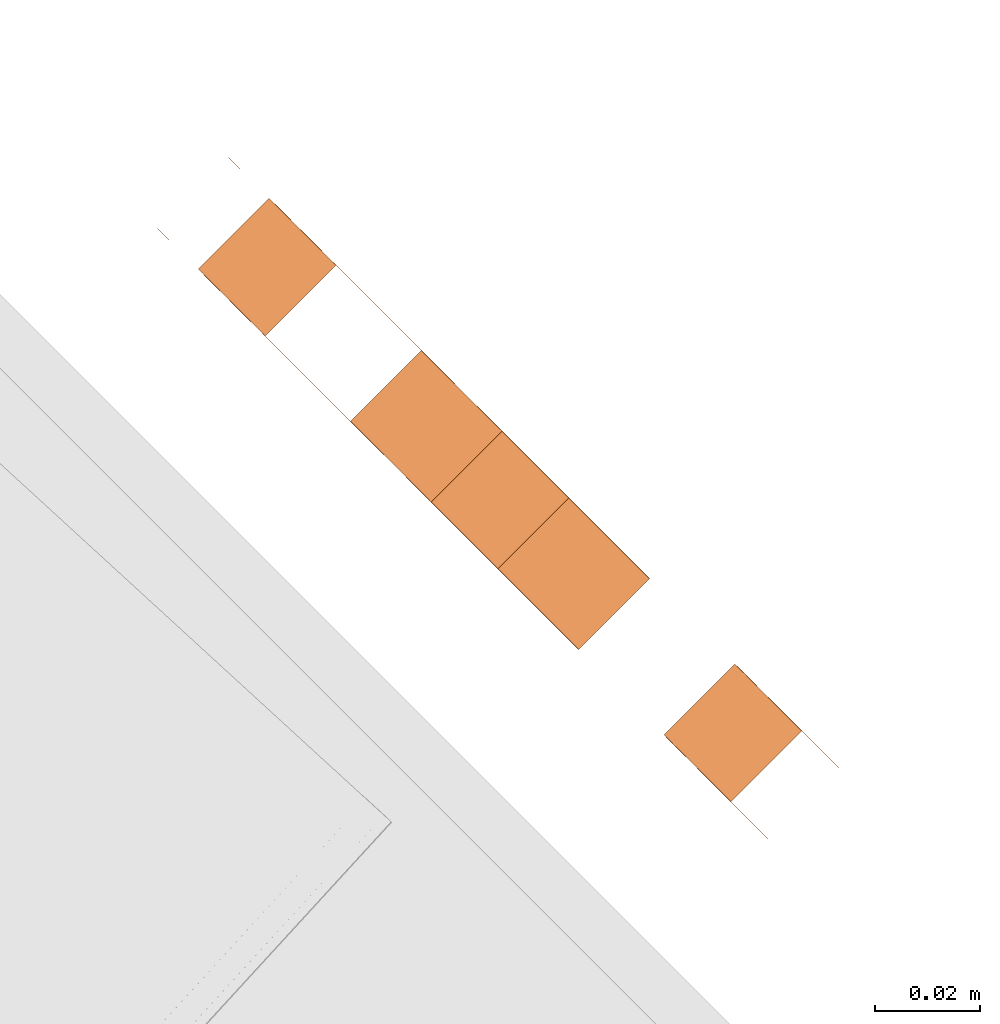
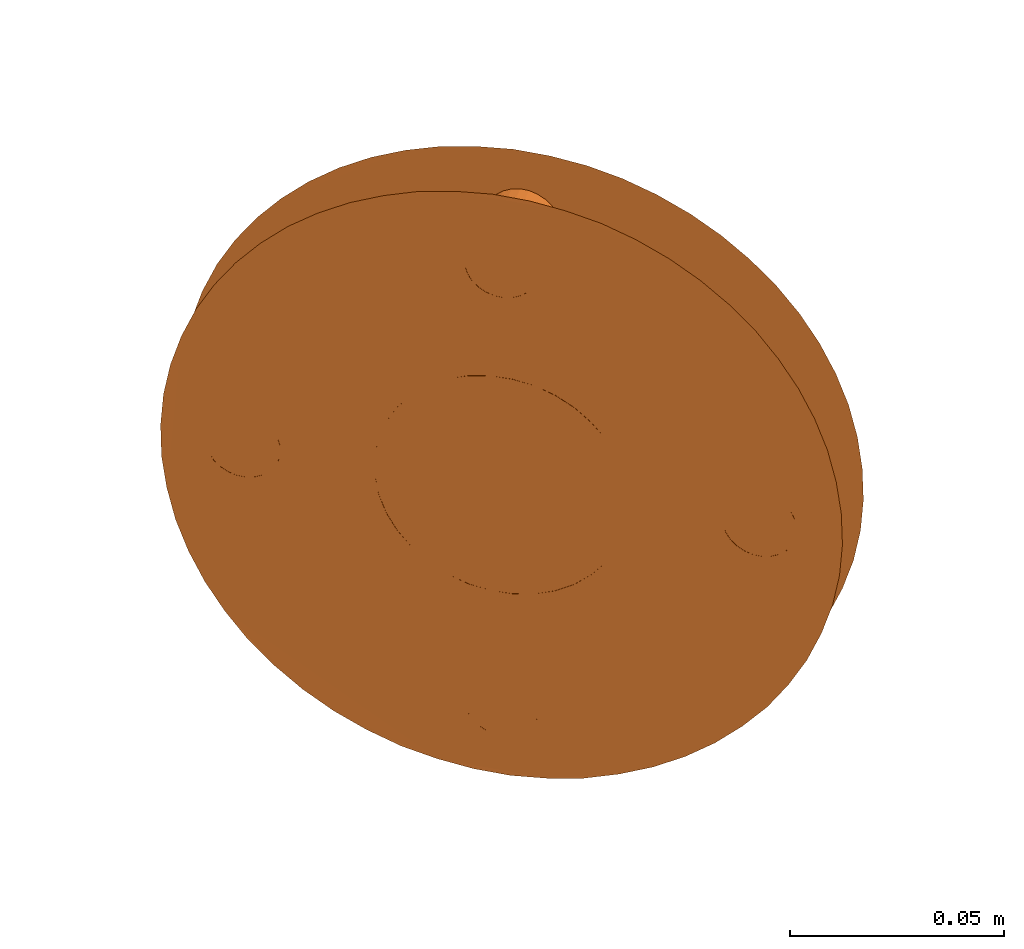
# One storey, part 94 of 126: 1 proxy.
"""IFC2X3 building model written with IfcOpenShell, lengths in millimetres."""

from ifc_helpers import new_model, si_unit, origin, origin_with_axes, place, context, project, spatial, faceted_brep, material, element, save


model = new_model("IFC2X3")

# Units and contexts
context_of_model_1 = context(None, 3, precision=0.1, world=origin())
context_of_model_2 = context(None, 3, precision=0.1, world=origin())
ifc_project = project(units=[si_unit("LENGTHUNIT", "METRE", prefix="MILLI"), si_unit("AREAUNIT", "SQUARE_METRE", prefix="CENTI"), si_unit("VOLUMEUNIT", "CUBIC_METRE", prefix="CENTI"), si_unit("MASSUNIT", "GRAM", prefix="KILO")], contexts=[context_of_model_1, context_of_model_2])

# Site, building, storey
site_placement = place(None, origin_with_axes())
site = spatial("IfcSite", under=ifc_project, at=site_placement, CompositionType="ELEMENT")
building_placement = place(site_placement, origin_with_axes())
building = spatial("IfcBuilding", under=site, at=building_placement, CompositionType="ELEMENT")
storey_placement = place(building_placement, origin_with_axes())
storey = spatial("IfcBuildingStorey", under=building, at=storey_placement, CompositionType="ELEMENT")

# Proxy
ifc_material = material(Name="STAHL")
proxy_placement = place(storey_placement, origin_with_axes())
element("IfcBuildingElementProxy", 1, at=proxy_placement, inside=storey, material=ifc_material, Name="profile", context=context_of_model_2, shape_type="Brep", body=[
    faceted_brep([(13510.9, 13818.5, 1593.8), (13510.4, 13819.0, 1584.9), (13509.2, 13820.2, 1576.1), (13507.3, 13822.1, 1567.6), (13504.8, 13824.6, 1559.3), (13501.7, 13827.7, 1551.6), (13498.0, 13831.3, 1544.3), (13493.8, 13835.6, 1537.7), (13489.1, 13840.3, 1531.7), (13484.0, 13845.4, 1526.5), (13478.5, 13850.9, 1522.1), (13472.7, 13856.7, 1518.6), (13466.6, 13862.7, 1515.9), (13460.4, 13868.9, 1514.3), (13454.1, 13875.2, 1513.5), (13447.8, 13881.5, 1513.8), (13441.6, 13887.8, 1515.0), (13435.4, 13893.9, 1517.1), (13429.5, 13899.9, 1520.2), (13423.8, 13905.5, 1524.2), (13418.5, 13910.8, 1529.0), (13413.6, 13915.8, 1534.6), (13409.1, 13920.2, 1540.9), (13405.2, 13924.2, 1547.9), (13401.8, 13927.6, 1555.4), (13399.0, 13930.4, 1563.4), (13396.8, 13932.6, 1571.8), (13395.3, 13934.1, 1580.5), (13407.8, 13948.4, 1589.3), (13408.7, 13947.5, 1580.5), (13410.2, 13946.0, 1571.8), (13412.4, 13943.8, 1563.4), (13415.2, 13941.0, 1555.4), (13418.6, 13937.6, 1547.9), (13422.6, 13933.7, 1540.9), (13427.0, 13929.2, 1534.6), (13432.0, 13924.3, 1529.0), (13437.3, 13919.0, 1524.2), (13442.9, 13913.3, 1520.2), (13448.9, 13907.4, 1517.1), (13455.0, 13901.2, 1515.0), (13461.3, 13895.0, 1513.8), (13467.6, 13888.7, 1513.5), (13473.9, 13882.4, 1514.3), (13480.1, 13876.2, 1515.9), (13486.1, 13870.1, 1518.6), (13491.9, 13864.3, 1522.1), (13497.4, 13858.8, 1526.5), (13502.5, 13853.7, 1531.7), (13507.2, 13849.0, 1537.7), (13511.5, 13844.8, 1544.3), (13515.1, 13841.1, 1551.6), (13518.2, 13838.0, 1559.3), (13520.7, 13835.5, 1567.6), (13522.6, 13833.6, 1576.1), (13523.8, 13832.4, 1584.9), (13524.3, 13831.9, 1593.8), (13524.1, 13832.1, 1602.7), (13523.3, 13833.0, 1611.5), (13521.8, 13834.5, 1620.2), (13519.6, 13836.7, 1628.6), (13516.8, 13839.5, 1636.6), (13513.4, 13842.9, 1644.1), (13509.4, 13846.8, 1651.1), (13504.9, 13851.3, 1657.4), (13500.0, 13856.2, 1663.0), (13494.7, 13861.5, 1667.8), (13489.0, 13867.2, 1671.8), (13483.1, 13873.1, 1674.9), (13477.0, 13879.3, 1677.0), (13470.7, 13885.5, 1678.2), (13464.4, 13891.8, 1678.5), (13458.1, 13898.1, 1677.7), (13451.9, 13904.3, 1676.1), (13445.9, 13910.4, 1673.4), (13440.1, 13916.2, 1669.9), (13434.6, 13921.7, 1665.5), (13429.4, 13926.8, 1660.3), (13424.7, 13931.5, 1654.3), (13420.5, 13935.7, 1647.7), (13416.8, 13939.4, 1640.4), (13413.7, 13942.5, 1632.7), (13411.2, 13945.0, 1624.4), (13409.4, 13946.9, 1615.9), (13408.2, 13948.1, 1607.1), (13407.7, 13948.6, 1598.2), (13394.4, 13935.0, 1589.3), (13394.2, 13935.1, 1598.2), (13394.7, 13934.6, 1607.1), (13395.9, 13933.4, 1615.9), (13397.8, 13931.6, 1624.4), (13400.3, 13929.1, 1632.7), (13403.4, 13926.0, 1640.4), (13407.1, 13922.3, 1647.7), (13411.3, 13918.1, 1654.3), (13416.0, 13913.4, 1660.3), (13421.1, 13908.2, 1665.5), (13426.6, 13902.7, 1669.9), (13432.4, 13896.9, 1673.4), (13438.5, 13890.9, 1676.1), (13444.7, 13884.7, 1677.7), (13451.0, 13878.4, 1678.5), (13457.3, 13872.1, 1678.2), (13463.5, 13865.8, 1677.0), (13469.7, 13859.7, 1674.9), (13475.6, 13853.8, 1671.8), (13481.3, 13848.1, 1667.8), (13486.6, 13842.8, 1663.0), (13491.5, 13837.9, 1657.4), (13496.0, 13833.4, 1651.1), (13499.9, 13829.4, 1644.1), (13503.3, 13826.0, 1636.6), (13506.1, 13823.2, 1628.6), (13508.3, 13821.0, 1620.2), (13509.8, 13819.5, 1611.5), (13510.7, 13818.7, 1602.7), (13481.4, 13874.9, 1574.3), (13478.5, 13877.8, 1570.8), (13465.0, 13864.3, 1570.8), (13467.9, 13861.4, 1574.3), (13475.2, 13881.1, 1568.1), (13461.7, 13867.6, 1568.1), (13471.6, 13884.6, 1566.3), (13458.2, 13871.2, 1566.3), (13467.9, 13888.4, 1565.4), (13454.4, 13874.9, 1565.4), (13464.1, 13892.1, 1565.4), (13450.7, 13878.7, 1565.4), (13460.4, 13895.9, 1566.3), (13446.9, 13882.4, 1566.3), (13456.8, 13899.4, 1568.1), (13443.4, 13886.0, 1568.1), (13453.5, 13902.7, 1570.8), (13440.1, 13889.3, 1570.8), (13450.6, 13905.6, 1574.3), (13437.2, 13892.2, 1574.3), (13448.2, 13908.1, 1578.4), (13434.7, 13894.6, 1578.4), (13446.3, 13910.0, 1583.0), (13432.8, 13896.5, 1583.0), (13445.0, 13911.3, 1588.0), (13431.5, 13897.8, 1588.0), (13444.3, 13911.9, 1593.3), (13430.9, 13898.5, 1593.3), (13444.3, 13911.9, 1598.7), (13430.9, 13898.5, 1598.7), (13445.0, 13911.3, 1604.0), (13431.5, 13897.8, 1604.0), (13446.3, 13910.0, 1609.0), (13432.8, 13896.5, 1609.0), (13448.2, 13908.1, 1613.6), (13434.7, 13894.6, 1613.6), (13450.6, 13905.6, 1617.7), (13437.2, 13892.2, 1617.7), (13514.7, 13841.6, 1589.6), (13513.5, 13842.8, 1588.3), (13500.0, 13829.3, 1588.3), (13501.2, 13828.1, 1589.6), (13512.1, 13844.2, 1587.4), (13498.6, 13830.7, 1587.4), (13510.6, 13845.7, 1587.0), (13497.1, 13832.2, 1587.0), (13509.0, 13847.2, 1587.1), (13495.6, 13833.8, 1587.1), (13507.6, 13848.7, 1587.8), (13494.1, 13835.2, 1587.8), (13506.3, 13850.0, 1588.9), (13492.8, 13836.5, 1588.9), (13505.2, 13851.1, 1590.4), (13491.7, 13837.6, 1590.4), (13504.4, 13851.9, 1592.3), (13490.9, 13838.4, 1592.3), (13503.9, 13852.3, 1594.4), (13490.5, 13838.9, 1594.4), (13503.8, 13852.4, 1596.5), (13490.4, 13839.0, 1596.5), (13504.1, 13852.1, 1598.7), (13490.7, 13838.7, 1598.7), (13504.7, 13851.5, 1600.7), (13491.3, 13838.1, 1600.7), (13505.7, 13850.6, 1602.4), (13492.2, 13837.1, 1602.4), (13426.3, 13929.9, 1589.6), (13425.1, 13931.2, 1588.3), (13411.6, 13917.7, 1588.3), (13412.9, 13916.5, 1589.6), (13423.7, 13932.6, 1587.4), (13410.2, 13919.1, 1587.4), (13422.2, 13934.1, 1587.0), (13408.7, 13920.6, 1587.0), (13420.6, 13935.6, 1587.1), (13407.2, 13922.2, 1587.1), (13419.2, 13937.1, 1587.8), (13405.7, 13923.6, 1587.8), (13417.9, 13938.4, 1588.9), (13404.4, 13924.9, 1588.9), (13416.8, 13939.5, 1590.4), (13403.3, 13926.0, 1590.4), (13416.0, 13940.2, 1592.3), (13402.6, 13926.8, 1592.3), (13415.5, 13940.7, 1594.4), (13402.1, 13927.3, 1594.4), (13415.4, 13940.8, 1596.5), (13402.0, 13927.4, 1596.5), (13415.7, 13940.5, 1598.7), (13402.3, 13927.1, 1598.7), (13416.3, 13939.9, 1600.7), (13402.9, 13926.5, 1600.7), (13417.3, 13938.9, 1602.4), (13403.9, 13925.5, 1602.4), (13469.3, 13887.0, 1525.8), (13455.8, 13873.5, 1525.8), (13457.1, 13872.3, 1527.1), (13470.5, 13885.7, 1527.1), (13467.9, 13888.4, 1524.9), (13454.4, 13874.9, 1524.9), (13466.4, 13889.9, 1524.5), (13452.9, 13876.4, 1524.5), (13464.8, 13891.4, 1524.6), (13451.4, 13878.0, 1524.6), (13463.4, 13892.9, 1525.3), (13449.9, 13879.4, 1525.3), (13462.1, 13894.2, 1526.4), (13448.6, 13880.7, 1526.4), (13461.0, 13895.3, 1527.9), (13447.5, 13881.8, 1527.9), (13460.2, 13896.1, 1529.8), (13446.7, 13882.6, 1529.8), (13459.7, 13896.5, 1531.9), (13446.3, 13883.1, 1531.9), (13459.6, 13896.6, 1534.0), (13446.2, 13883.2, 1534.0), (13459.9, 13896.3, 1536.2), (13446.5, 13882.9, 1536.2), (13460.5, 13895.7, 1538.2), (13447.1, 13882.3, 1538.2), (13461.5, 13894.7, 1539.9), (13448.1, 13881.3, 1539.9), (13470.5, 13885.7, 1652.1), (13469.3, 13887.0, 1650.8), (13455.8, 13873.5, 1650.8), (13457.1, 13872.3, 1652.1), (13467.9, 13888.4, 1649.9), (13454.4, 13874.9, 1649.9), (13466.4, 13889.9, 1649.5), (13452.9, 13876.4, 1649.5), (13464.8, 13891.4, 1649.6), (13451.4, 13878.0, 1649.6), (13463.4, 13892.9, 1650.3), (13449.9, 13879.4, 1650.3), (13462.1, 13894.2, 1651.4), (13448.6, 13880.7, 1651.4), (13461.0, 13895.3, 1652.9), (13447.5, 13881.8, 1652.9), (13460.2, 13896.1, 1654.8), (13446.7, 13882.6, 1654.8), (13459.7, 13896.5, 1656.9), (13446.3, 13883.1, 1656.9), (13459.6, 13896.6, 1659.0), (13446.2, 13883.2, 1659.0), (13459.9, 13896.3, 1661.2), (13446.5, 13882.9, 1661.2), (13460.5, 13895.7, 1663.2), (13447.1, 13882.3, 1663.2), (13461.5, 13894.7, 1664.9), (13448.1, 13881.3, 1664.9), (13462.7, 13893.5, 1666.2), (13449.3, 13880.1, 1666.2), (13464.1, 13892.1, 1667.1), (13450.7, 13878.7, 1667.1), (13465.6, 13890.6, 1667.5), (13452.2, 13877.2, 1667.5), (13467.1, 13889.1, 1667.4), (13453.7, 13875.7, 1667.4), (13468.6, 13887.6, 1666.7), (13455.2, 13874.2, 1666.7), (13469.9, 13886.3, 1665.6), (13456.5, 13872.9, 1665.6), (13471.0, 13885.2, 1664.1), (13457.6, 13871.8, 1664.1), (13471.8, 13884.4, 1662.2), (13458.4, 13871.0, 1662.2), (13472.2, 13884.0, 1660.1), (13458.8, 13870.6, 1660.1), (13472.3, 13883.9, 1658.0), (13458.9, 13870.5, 1658.0), (13472.1, 13884.2, 1655.8), (13458.6, 13870.7, 1655.8), (13471.4, 13884.8, 1653.8), (13458.0, 13871.4, 1653.8), (13462.7, 13893.5, 1541.2), (13449.3, 13880.1, 1541.2), (13464.1, 13892.1, 1542.1), (13450.7, 13878.7, 1542.1), (13465.6, 13890.6, 1542.5), (13452.2, 13877.2, 1542.5), (13467.1, 13889.1, 1542.4), (13453.7, 13875.7, 1542.4), (13468.6, 13887.6, 1541.7), (13455.2, 13874.2, 1541.7), (13469.9, 13886.3, 1540.6), (13456.5, 13872.9, 1540.6), (13471.0, 13885.2, 1539.1), (13457.6, 13871.8, 1539.1), (13471.8, 13884.4, 1537.2), (13458.4, 13871.0, 1537.2), (13472.2, 13884.0, 1535.1), (13458.8, 13870.6, 1535.1), (13472.3, 13883.9, 1533.0), (13458.9, 13870.5, 1533.0), (13472.1, 13884.2, 1530.8), (13458.6, 13870.7, 1530.8), (13471.4, 13884.8, 1528.8), (13458.0, 13871.4, 1528.8), (13418.5, 13937.7, 1603.7), (13405.1, 13924.3, 1603.7), (13419.9, 13936.3, 1604.6), (13406.5, 13922.9, 1604.6), (13421.4, 13934.8, 1605.0), (13408.0, 13921.4, 1605.0), (13422.9, 13933.3, 1604.9), (13409.5, 13919.9, 1604.9), (13424.4, 13931.8, 1604.2), (13411.0, 13918.4, 1604.2), (13425.7, 13930.5, 1603.1), (13412.3, 13917.1, 1603.1), (13426.8, 13929.4, 1601.6), (13413.4, 13916.0, 1601.6), (13427.6, 13928.6, 1599.7), (13414.2, 13915.2, 1599.7), (13428.1, 13928.2, 1597.6), (13414.6, 13914.7, 1597.6), (13428.1, 13928.1, 1595.5), (13414.7, 13914.7, 1595.5), (13427.9, 13928.4, 1593.3), (13414.4, 13914.9, 1593.3), (13427.2, 13929.0, 1591.3), (13413.8, 13915.6, 1591.3), (13506.9, 13849.3, 1603.7), (13493.5, 13835.9, 1603.7), (13508.3, 13847.9, 1604.6), (13494.9, 13834.5, 1604.6), (13509.8, 13846.4, 1605.0), (13496.4, 13833.0, 1605.0), (13511.3, 13844.9, 1604.9), (13497.9, 13831.5, 1604.9), (13512.8, 13843.4, 1604.2), (13499.4, 13830.0, 1604.2), (13514.1, 13842.1, 1603.1), (13500.7, 13828.7, 1603.1), (13515.2, 13841.0, 1601.6), (13501.8, 13827.6, 1601.6), (13516.0, 13840.3, 1599.7), (13502.5, 13826.8, 1599.7), (13516.4, 13839.8, 1597.6), (13503.0, 13826.4, 1597.6), (13516.5, 13839.7, 1595.5), (13503.1, 13826.3, 1595.5), (13516.3, 13840.0, 1593.3), (13502.8, 13826.5, 1593.3), (13515.6, 13840.6, 1591.3), (13502.2, 13827.2, 1591.3), (13483.8, 13872.4, 1578.4), (13485.7, 13870.5, 1583.0), (13487.0, 13869.2, 1588.0), (13487.6, 13868.6, 1593.3), (13487.6, 13868.6, 1598.7), (13487.0, 13869.2, 1604.0), (13485.7, 13870.5, 1609.0), (13483.8, 13872.4, 1613.6), (13481.4, 13874.9, 1617.7), (13478.5, 13877.8, 1621.2), (13475.2, 13881.1, 1623.9), (13471.6, 13884.6, 1625.7), (13467.9, 13888.4, 1626.6), (13464.1, 13892.1, 1626.6), (13460.4, 13895.9, 1625.7), (13456.8, 13899.4, 1623.9), (13453.5, 13902.7, 1621.2), (13470.4, 13859.0, 1613.6), (13472.3, 13857.1, 1609.0), (13473.6, 13855.8, 1604.0), (13474.2, 13855.2, 1598.7), (13474.2, 13855.2, 1593.3), (13473.6, 13855.8, 1588.0), (13472.3, 13857.1, 1583.0), (13470.4, 13859.0, 1578.4), (13440.1, 13889.3, 1621.2), (13443.4, 13886.0, 1623.9), (13446.9, 13882.4, 1625.7), (13450.7, 13878.7, 1626.6), (13454.4, 13874.9, 1626.6), (13458.2, 13871.2, 1625.7), (13461.7, 13867.6, 1623.9), (13465.0, 13864.3, 1621.2), (13467.9, 13861.4, 1617.7)], [[[0, 1, 2, 3, 4, 5, 6, 7, 8, 9, 10, 11, 12, 13, 14, 15, 16, 17, 18, 19, 20, 21, 22, 23, 24, 25, 26, 27, 28, 29, 30, 31, 32, 33, 34, 35, 36, 37, 38, 39, 40, 41, 42, 43, 44, 45, 46, 47, 48, 49, 50, 51, 52, 53, 54, 55, 56, 57, 58, 59, 60, 61, 62, 63, 64, 65, 66, 67, 68, 69, 70, 71, 72, 73, 74, 75, 76, 77, 78, 79, 80, 81, 82, 83, 84, 85, 28, 27, 86, 87, 88, 89, 90, 91, 92, 93, 94, 95, 96, 97, 98, 99, 100, 101, 102, 103, 104, 105, 106, 107, 108, 109, 110, 111, 112, 113, 114, 115]], [[116, 117, 118, 119]], [[117, 120, 121, 118]], [[120, 122, 123, 121]], [[122, 124, 125, 123]], [[124, 126, 127, 125]], [[126, 128, 129, 127]], [[128, 130, 131, 129]], [[130, 132, 133, 131]], [[132, 134, 135, 133]], [[134, 136, 137, 135]], [[136, 138, 139, 137]], [[138, 140, 141, 139]], [[140, 142, 143, 141]], [[142, 144, 145, 143]], [[144, 146, 147, 145]], [[146, 148, 149, 147]], [[148, 150, 151, 149]], [[152, 153, 151, 150]], [[154, 155, 156, 157]], [[155, 158, 159, 156]], [[158, 160, 161, 159]], [[160, 162, 163, 161]], [[162, 164, 165, 163]], [[164, 166, 167, 165]], [[166, 168, 169, 167]], [[168, 170, 171, 169]], [[170, 172, 173, 171]], [[172, 174, 175, 173]], [[174, 176, 177, 175]], [[176, 178, 179, 177]], [[178, 180, 181, 179]], [[182, 183, 184, 185]], [[183, 186, 187, 184]], [[186, 188, 189, 187]], [[188, 190, 191, 189]], [[190, 192, 193, 191]], [[192, 194, 195, 193]], [[194, 196, 197, 195]], [[196, 198, 199, 197]], [[198, 200, 201, 199]], [[200, 202, 203, 201]], [[202, 204, 205, 203]], [[204, 206, 207, 205]], [[206, 208, 209, 207]], [[210, 211, 212, 213]], [[214, 215, 211, 210]], [[216, 217, 215, 214]], [[218, 219, 217, 216]], [[220, 221, 219, 218]], [[222, 223, 221, 220]], [[224, 225, 223, 222]], [[226, 227, 225, 224]], [[228, 229, 227, 226]], [[230, 231, 229, 228]], [[232, 233, 231, 230]], [[234, 235, 233, 232]], [[234, 236, 237, 235]], [[238, 239, 240, 241]], [[239, 242, 243, 240]], [[242, 244, 245, 243]], [[244, 246, 247, 245]], [[246, 248, 249, 247]], [[248, 250, 251, 249]], [[250, 252, 253, 251]], [[252, 254, 255, 253]], [[254, 256, 257, 255]], [[256, 258, 259, 257]], [[258, 260, 261, 259]], [[260, 262, 263, 261]], [[262, 264, 265, 263]], [[266, 267, 265, 264]], [[266, 268, 269, 267]], [[268, 270, 271, 269]], [[270, 272, 273, 271]], [[272, 274, 275, 273]], [[274, 276, 277, 275]], [[276, 278, 279, 277]], [[278, 280, 281, 279]], [[280, 282, 283, 281]], [[282, 284, 285, 283]], [[284, 286, 287, 285]], [[286, 288, 289, 287]], [[288, 238, 241, 289]], [[290, 291, 237, 236]], [[290, 292, 293, 291]], [[292, 294, 295, 293]], [[294, 296, 297, 295]], [[296, 298, 299, 297]], [[298, 300, 301, 299]], [[300, 302, 303, 301]], [[302, 304, 305, 303]], [[304, 306, 307, 305]], [[306, 308, 309, 307]], [[308, 310, 311, 309]], [[310, 312, 313, 311]], [[312, 213, 212, 313]], [[314, 315, 209, 208]], [[316, 317, 315, 314]], [[318, 319, 317, 316]], [[320, 321, 319, 318]], [[322, 323, 321, 320]], [[324, 325, 323, 322]], [[326, 327, 325, 324]], [[328, 329, 327, 326]], [[330, 331, 329, 328]], [[332, 333, 331, 330]], [[334, 335, 333, 332]], [[336, 337, 335, 334]], [[182, 185, 337, 336]], [[338, 339, 181, 180]], [[338, 340, 341, 339]], [[340, 342, 343, 341]], [[342, 344, 345, 343]], [[344, 346, 347, 345]], [[346, 348, 349, 347]], [[348, 350, 351, 349]], [[350, 352, 353, 351]], [[352, 354, 355, 353]], [[354, 356, 357, 355]], [[356, 358, 359, 357]], [[358, 360, 361, 359]], [[360, 154, 157, 361]], [[56, 55, 54, 53, 52, 51, 50, 49, 48, 47, 46, 45, 44, 43, 42, 41, 40, 39, 38, 37, 36, 35, 34, 33, 32, 31, 30, 190, 188, 186, 183, 182, 336, 334, 332, 330, 328, 326, 324, 322, 150, 148, 146, 144, 142, 140, 138, 136, 134, 132, 130, 128, 126, 124, 122, 120, 117, 304, 302, 300, 298, 296, 294, 292, 290, 236, 234, 232, 230, 228, 226, 224, 222, 220, 218, 216, 214, 210, 213, 312, 310, 308, 306, 304, 117, 116, 362, 363, 364, 365, 366, 367, 368, 369, 338, 180, 178, 176, 174, 172, 170, 168, 166, 164, 162, 160, 158, 155, 154, 360, 358, 356, 354, 352, 350, 348, 346, 344, 342, 340, 338, 369, 370, 371, 372, 373, 374, 375, 376, 377, 378, 254, 252, 250, 248, 246, 244, 242, 239, 238, 288, 286, 284, 282, 280, 278, 276, 274, 272, 270, 268, 266, 264, 262, 260, 258, 256, 254, 378, 152, 150, 322, 320, 318, 316, 314, 208, 206, 204, 202, 200, 198, 196, 194, 192, 190, 30, 29, 28, 85, 84, 83, 82, 81, 80, 79, 78, 77, 76, 75, 74, 73, 72, 71, 70, 69, 68, 67, 66, 65, 64, 63, 62, 61, 60, 59, 58, 57]], [[0, 115, 114, 113, 112, 111, 110, 109, 108, 107, 106, 105, 104, 103, 102, 101, 100, 99, 98, 97, 96, 95, 94, 93, 92, 91, 90, 89, 88, 87, 86, 27, 26, 25, 24, 23, 22, 21, 20, 19, 18, 17, 16, 15, 14, 13, 12, 11, 10, 9, 8, 7, 6, 5, 4, 3, 161, 163, 165, 167, 169, 171, 173, 175, 177, 179, 181, 339, 379, 380, 381, 382, 383, 384, 385, 386, 119, 118, 121, 123, 125, 127, 129, 131, 133, 235, 237, 291, 293, 295, 297, 299, 301, 303, 305, 307, 309, 311, 313, 212, 211, 215, 217, 219, 221, 223, 225, 227, 229, 231, 233, 235, 133, 135, 137, 139, 141, 143, 145, 147, 149, 151, 323, 325, 327, 329, 331, 333, 335, 337, 185, 184, 187, 189, 191, 193, 195, 197, 199, 201, 203, 205, 207, 209, 315, 317, 319, 321, 323, 151, 153, 387, 388, 389, 390, 391, 392, 393, 394, 289, 241, 240, 243, 245, 247, 249, 251, 253, 255, 257, 259, 261, 263, 265, 267, 269, 271, 273, 275, 277, 279, 281, 283, 285, 287, 289, 394, 395, 379, 339, 341, 343, 345, 347, 349, 351, 353, 355, 357, 359, 361, 157, 156, 159, 161, 3, 2, 1]], [[152, 378, 387, 153]], [[378, 377, 388, 387]], [[377, 376, 389, 388]], [[376, 375, 390, 389]], [[375, 374, 391, 390]], [[374, 373, 392, 391]], [[373, 372, 393, 392]], [[372, 371, 394, 393]], [[371, 370, 395, 394]], [[370, 369, 379, 395]], [[369, 368, 380, 379]], [[368, 367, 381, 380]], [[367, 366, 382, 381]], [[366, 365, 383, 382]], [[365, 364, 384, 383]], [[364, 363, 385, 384]], [[363, 362, 386, 385]], [[362, 116, 119, 386]]]),
])

save(model, "model.ifc")
